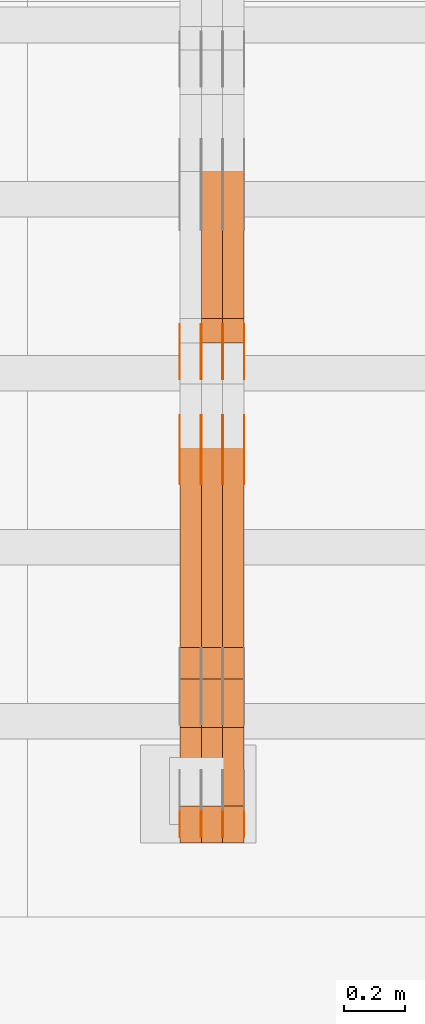
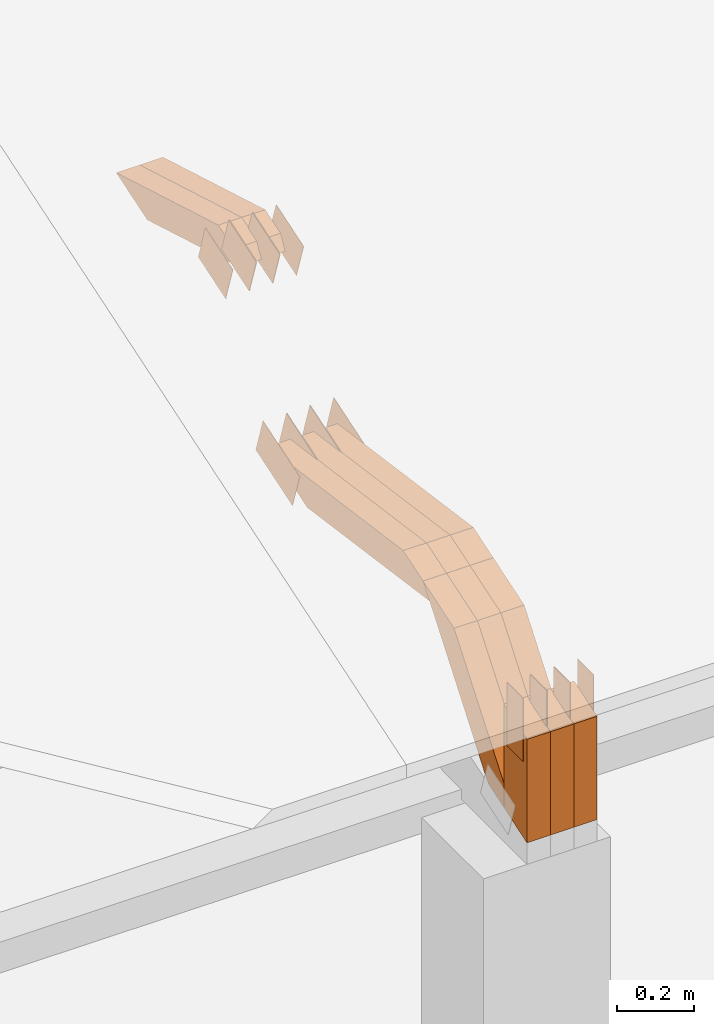
# One storey, part 264 of 385: 29 proxies.
"""IFC2X3 building model written with IfcOpenShell, lengths in millimetres."""

from ifc_helpers import new_model, entity, si_unit, converted_unit, derived_unit, direction, frame, frame_2d, origin, place, context, subcontext, project, spatial, polyline, rectangle, outline, extrude, source, transform, mapped, material, type_object, type_shapes, element, save


model = new_model("IFC2X3")

# Units and contexts
model_context = context("Model", 3, precision=0.01, world=origin(), true_north=direction((6.12303176911189e-17, 1.0)))
body_context = subcontext(model_context, "Body", "Model", "MODEL_VIEW")
ifc_project = project(units=[si_unit("LENGTHUNIT", "METRE", prefix="MILLI"), si_unit("AREAUNIT", "SQUARE_METRE"), si_unit("VOLUMEUNIT", "CUBIC_METRE"), converted_unit("PLANEANGLEUNIT", "DEGREE", entity("IfcRatioMeasure", 0.0174532925199433), si_unit("PLANEANGLEUNIT", "RADIAN"), dimensions=[0, 0, 0, 0, 0, 0, 0]), si_unit("MASSUNIT", "GRAM", prefix="KILO"), derived_unit("MASSDENSITYUNIT", [(si_unit("MASSUNIT", "GRAM", prefix="KILO"), 1), (si_unit("LENGTHUNIT", "METRE"), -3)]), si_unit("TIMEUNIT", "SECOND"), si_unit("FREQUENCYUNIT", "HERTZ"), si_unit("THERMODYNAMICTEMPERATUREUNIT", "DEGREE_CELSIUS"), derived_unit("THERMALTRANSMITTANCEUNIT", [(si_unit("MASSUNIT", "GRAM", prefix="KILO"), 1), (si_unit("THERMODYNAMICTEMPERATUREUNIT", "KELVIN"), -1), (si_unit("TIMEUNIT", "SECOND"), -3)]), derived_unit("VOLUMETRICFLOWRATEUNIT", [(si_unit("LENGTHUNIT", "METRE"), 3), (si_unit("TIMEUNIT", "SECOND"), -1)]), si_unit("ELECTRICCURRENTUNIT", "AMPERE"), si_unit("ELECTRICVOLTAGEUNIT", "VOLT"), si_unit("POWERUNIT", "WATT"), si_unit("FORCEUNIT", "NEWTON", prefix="KILO"), si_unit("ILLUMINANCEUNIT", "LUX"), si_unit("LUMINOUSFLUXUNIT", "LUMEN"), si_unit("LUMINOUSINTENSITYUNIT", "CANDELA"), derived_unit("USERDEFINED", [(si_unit("MASSUNIT", "GRAM", prefix="KILO"), -1), (si_unit("LENGTHUNIT", "METRE"), -2), (si_unit("TIMEUNIT", "SECOND"), 3), (si_unit("LUMINOUSFLUXUNIT", "LUMEN"), 1)]), derived_unit("LINEARVELOCITYUNIT", [(si_unit("LENGTHUNIT", "METRE"), 1), (si_unit("TIMEUNIT", "SECOND"), -1)]), si_unit("PRESSUREUNIT", "PASCAL"), derived_unit("USERDEFINED", [(si_unit("LENGTHUNIT", "METRE"), -2), (si_unit("MASSUNIT", "GRAM", prefix="KILO"), 1), (si_unit("TIMEUNIT", "SECOND"), -2)])], contexts=[model_context])

# Site, building, storey
site_placement = place(None, origin())
site = spatial("IfcSite", under=ifc_project, at=site_placement, CompositionType="ELEMENT")
building_placement = place(site_placement, origin())
building = spatial("IfcBuilding", under=site, at=building_placement, CompositionType="ELEMENT")
storey_placement = place(building_placement, origin())
storey = spatial("IfcBuildingStorey", under=building, at=storey_placement, Name="Default", CompositionType="ELEMENT", Elevation=0.0)

# Proxies
ifc_material_1 = material(Name="IfcSurfaceStyle #511846")
building_element_proxy_type_1 = type_object("IfcBuildingElementProxyType", PredefinedType="NOTDEFINED", material=ifc_material_1)
shared_shape_1 = source(origin(), body_context, "Body", "SweptSolid", [
    extrude(outline(polyline([(-99.9998204243802, -60.000067376167), (99.9998338462265, -60.000067376167), (99.9998204243802, 60.000067376167), (-99.9998338462265, 60.000067376167), (-99.9998204243802, -60.000067376167)])), frame((100.000602015329, 60.0001864986889, 0.0), z_axis=(0.0, 0.0, 1.0), x_axis=(-1.0, 0.0, 0.0)), (0.0, 0.0, 1.0), 1.3),
])
type_shapes(building_element_proxy_type_1, [shared_shape_1])
proxy_1_placement = place(building_placement, frame((42386.3, 4114.85465165112, 513.097031388771), z_axis=(-1.0, 0.0, 0.0), x_axis=(0.0, 0.951056516295124, 0.309016994375039)))
element("IfcBuildingElementProxy", 1, at=proxy_1_placement, inside=storey, type_object=building_element_proxy_type_1, material=ifc_material_1, context=body_context, shape_type="MappedRepresentation", body=[
    mapped(shared_shape_1, transform((0.0, 0.0, 0.0), scale=1.0)),
])
ifc_material_2 = material(Name="IfcSurfaceStyle #511789")
building_element_proxy_type_2 = type_object("IfcBuildingElementProxyType", PredefinedType="NOTDEFINED", material=ifc_material_2)
shared_shape_2 = source(origin(), body_context, "Body", "SweptSolid", [
    extrude(outline(polyline([(-99.9998204243802, -60.000067376167), (99.9998338462265, -60.000067376167), (99.9998204243802, 60.000067376167), (-99.9998338462265, 60.000067376167), (-99.9998204243802, -60.000067376167)])), frame((100.000602015329, 60.0001864986889, 0.0), z_axis=(0.0, 0.0, 1.0), x_axis=(-1.0, 0.0, 0.0)), (0.0, 0.0, 1.0), 1.3),
])
type_shapes(building_element_proxy_type_2, [shared_shape_2])
proxy_2_placement = place(building_placement, frame((42315.0, 4114.85465165112, 513.097031388771), z_axis=(-1.0, 0.0, 0.0), x_axis=(0.0, 0.951056516295124, 0.309016994375039)))
element("IfcBuildingElementProxy", 2, at=proxy_2_placement, inside=storey, type_object=building_element_proxy_type_2, material=ifc_material_2, context=body_context, shape_type="MappedRepresentation", body=[
    mapped(shared_shape_2, transform((0.0, 0.0, 0.0), scale=1.0)),
])
ifc_material_3 = material(Name="IfcSurfaceStyle #511732")
building_element_proxy_type_3 = type_object("IfcBuildingElementProxyType", PredefinedType="NOTDEFINED", material=ifc_material_3)
shared_shape_3 = source(origin(), body_context, "Body", "SweptSolid", [
    extrude(outline(polyline([(-99.9998204243802, -60.000067376167), (99.9998338462265, -60.000067376167), (99.9998204243802, 60.000067376167), (-99.9998338462265, 60.000067376167), (-99.9998204243802, -60.000067376167)])), frame((100.000602015329, 60.0001864986889, 0.0), z_axis=(0.0, 0.0, 1.0), x_axis=(-1.0, 0.0, 0.0)), (0.0, 0.0, 1.0), 1.3),
])
type_shapes(building_element_proxy_type_3, [shared_shape_3])
proxy_3_placement = place(building_placement, frame((42316.3, 4114.85465165112, 513.097031388771), z_axis=(-1.0, 0.0, 0.0), x_axis=(0.0, 0.951056516295124, 0.309016994375039)))
element("IfcBuildingElementProxy", 3, at=proxy_3_placement, inside=storey, type_object=building_element_proxy_type_3, material=ifc_material_3, context=body_context, shape_type="MappedRepresentation", body=[
    mapped(shared_shape_3, transform((0.0, 0.0, 0.0), scale=1.0)),
])
ifc_material_4 = material(Name="IfcSurfaceStyle #511675")
building_element_proxy_type_4 = type_object("IfcBuildingElementProxyType", PredefinedType="NOTDEFINED", material=ifc_material_4)
shared_shape_4 = source(origin(), body_context, "Body", "SweptSolid", [
    extrude(outline(polyline([(-99.9998204243802, -60.000067376167), (99.9998338462265, -60.000067376167), (99.9998204243802, 60.000067376167), (-99.9998338462265, 60.000067376167), (-99.9998204243802, -60.000067376167)])), frame((100.000602015329, 60.0001864986889, 0.0), z_axis=(0.0, 0.0, 1.0), x_axis=(-1.0, 0.0, 0.0)), (0.0, 0.0, 1.0), 1.29999999999998),
])
type_shapes(building_element_proxy_type_4, [shared_shape_4])
proxy_4_placement = place(building_placement, frame((42245.0, 4114.85465165112, 513.097031388771), z_axis=(-1.0, 0.0, 0.0), x_axis=(0.0, 0.951056516295124, 0.309016994375039)))
element("IfcBuildingElementProxy", 4, at=proxy_4_placement, inside=storey, type_object=building_element_proxy_type_4, material=ifc_material_4, context=body_context, shape_type="MappedRepresentation", body=[
    mapped(shared_shape_4, transform((0.0, 0.0, 0.0), scale=1.0)),
])
ifc_material_5 = material(Name="IfcSurfaceStyle #511618")
building_element_proxy_type_5 = type_object("IfcBuildingElementProxyType", PredefinedType="NOTDEFINED", material=ifc_material_5)
shared_shape_5 = source(origin(), body_context, "Body", "SweptSolid", [
    extrude(outline(polyline([(-99.9998204243802, -60.000067376167), (99.9998338462265, -60.000067376167), (99.9998204243802, 60.000067376167), (-99.9998338462265, 60.000067376167), (-99.9998204243802, -60.000067376167)])), frame((100.000602015329, 60.0001864986889, 0.0), z_axis=(0.0, 0.0, 1.0), x_axis=(-1.0, 0.0, 0.0)), (0.0, 0.0, 1.0), 1.29999999999998),
])
type_shapes(building_element_proxy_type_5, [shared_shape_5])
proxy_5_placement = place(building_placement, frame((42246.3, 4114.85465165112, 513.097031388771), z_axis=(-1.0, 0.0, 0.0), x_axis=(0.0, 0.951056516295124, 0.309016994375039)))
element("IfcBuildingElementProxy", 5, at=proxy_5_placement, inside=storey, type_object=building_element_proxy_type_5, material=ifc_material_5, context=body_context, shape_type="MappedRepresentation", body=[
    mapped(shared_shape_5, transform((0.0, 0.0, 0.0), scale=1.0)),
])
ifc_material_6 = material(Name="IfcSurfaceStyle #511561")
building_element_proxy_type_6 = type_object("IfcBuildingElementProxyType", PredefinedType="NOTDEFINED", material=ifc_material_6)
shared_shape_6 = source(origin(), body_context, "Body", "SweptSolid", [
    extrude(outline(polyline([(-99.9998204243802, -60.000067376167), (99.9998338462265, -60.000067376167), (99.9998204243802, 60.000067376167), (-99.9998338462265, 60.000067376167), (-99.9998204243802, -60.000067376167)])), frame((100.000602015329, 60.0001864986889, 0.0), z_axis=(0.0, 0.0, 1.0), x_axis=(-1.0, 0.0, 0.0)), (0.0, 0.0, 1.0), 1.29999999999999),
])
type_shapes(building_element_proxy_type_6, [shared_shape_6])
proxy_6_placement = place(building_placement, frame((42175.0, 4114.85465165112, 513.097031388771), z_axis=(-1.0, 0.0, 0.0), x_axis=(0.0, 0.951056516295124, 0.309016994375039)))
element("IfcBuildingElementProxy", 6, at=proxy_6_placement, inside=storey, type_object=building_element_proxy_type_6, material=ifc_material_6, context=body_context, shape_type="MappedRepresentation", body=[
    mapped(shared_shape_6, transform((0.0, 0.0, 0.0), scale=1.0)),
])
ifc_material_7 = material(Name="IfcSurfaceStyle #504664")
building_element_proxy_type_7 = type_object("IfcBuildingElementProxyType", PredefinedType="NOTDEFINED", material=ifc_material_7)
shared_shape_7 = source(origin(), body_context, "Body", "SweptSolid", [
    extrude(outline(polyline([(-74.999865998172, -60.0000306612919), (74.999869989555, -60.0000306612919), (74.999865998172, 60.0000306612919), (-74.999869989555, 60.0000306612919), (-74.999865998172, -60.0000306612919)])), frame((75.0006726017528, 60.0001996460842, 0.0), z_axis=(0.0, 0.0, 1.0), x_axis=(-1.0, 0.0, 0.0)), (0.0, 0.0, 1.0), 1.3),
])
type_shapes(building_element_proxy_type_7, [shared_shape_7])
proxy_7_placement = place(building_placement, frame((42386.3, 4460.38978242656, 957.314497110567), z_axis=(-1.0, 0.0, 0.0), x_axis=(0.0, 0.951056516295154, 0.309016994374948)))
element("IfcBuildingElementProxy", 7, at=proxy_7_placement, inside=storey, type_object=building_element_proxy_type_7, material=ifc_material_7, context=body_context, shape_type="MappedRepresentation", body=[
    mapped(shared_shape_7, transform((0.0, 0.0, 0.0), scale=1.0)),
])
ifc_material_8 = material(Name="IfcSurfaceStyle #504607")
building_element_proxy_type_8 = type_object("IfcBuildingElementProxyType", PredefinedType="NOTDEFINED", material=ifc_material_8)
shared_shape_8 = source(origin(), body_context, "Body", "SweptSolid", [
    extrude(outline(polyline([(-74.999865998172, -60.0000306612919), (74.999869989555, -60.0000306612919), (74.999865998172, 60.0000306612919), (-74.999869989555, 60.0000306612919), (-74.999865998172, -60.0000306612919)])), frame((75.0006726017528, 60.0001996460842, 0.0), z_axis=(0.0, 0.0, 1.0), x_axis=(-1.0, 0.0, 0.0)), (0.0, 0.0, 1.0), 1.3),
])
type_shapes(building_element_proxy_type_8, [shared_shape_8])
proxy_8_placement = place(building_placement, frame((42315.0, 4460.38978242656, 957.314497110567), z_axis=(-1.0, 0.0, 0.0), x_axis=(0.0, 0.951056516295154, 0.309016994374948)))
element("IfcBuildingElementProxy", 8, at=proxy_8_placement, inside=storey, type_object=building_element_proxy_type_8, material=ifc_material_8, context=body_context, shape_type="MappedRepresentation", body=[
    mapped(shared_shape_8, transform((0.0, 0.0, 0.0), scale=1.0)),
])
ifc_material_9 = material(Name="IfcSurfaceStyle #504550")
building_element_proxy_type_9 = type_object("IfcBuildingElementProxyType", PredefinedType="NOTDEFINED", material=ifc_material_9)
shared_shape_9 = source(origin(), body_context, "Body", "SweptSolid", [
    extrude(outline(polyline([(-74.999865998172, -60.0000306612919), (74.999869989555, -60.0000306612919), (74.999865998172, 60.0000306612919), (-74.999869989555, 60.0000306612919), (-74.999865998172, -60.0000306612919)])), frame((75.0006726017528, 60.0001996460842, 0.0), z_axis=(0.0, 0.0, 1.0), x_axis=(-1.0, 0.0, 0.0)), (0.0, 0.0, 1.0), 1.3),
])
type_shapes(building_element_proxy_type_9, [shared_shape_9])
proxy_9_placement = place(building_placement, frame((42316.3, 4460.38978242656, 957.314497110567), z_axis=(-1.0, 0.0, 0.0), x_axis=(0.0, 0.951056516295154, 0.309016994374948)))
element("IfcBuildingElementProxy", 9, at=proxy_9_placement, inside=storey, type_object=building_element_proxy_type_9, material=ifc_material_9, context=body_context, shape_type="MappedRepresentation", body=[
    mapped(shared_shape_9, transform((0.0, 0.0, 0.0), scale=1.0)),
])
ifc_material_10 = material(Name="IfcSurfaceStyle #504493")
building_element_proxy_type_10 = type_object("IfcBuildingElementProxyType", PredefinedType="NOTDEFINED", material=ifc_material_10)
shared_shape_10 = source(origin(), body_context, "Body", "SweptSolid", [
    extrude(outline(polyline([(-74.999865998172, -60.0000306612919), (74.999869989555, -60.0000306612919), (74.999865998172, 60.0000306612919), (-74.999869989555, 60.0000306612919), (-74.999865998172, -60.0000306612919)])), frame((75.0006726017528, 60.0001996460842, 0.0), z_axis=(0.0, 0.0, 1.0), x_axis=(-1.0, 0.0, 0.0)), (0.0, 0.0, 1.0), 1.29999999999999),
])
type_shapes(building_element_proxy_type_10, [shared_shape_10])
proxy_10_placement = place(building_placement, frame((42245.0, 4460.38978242656, 957.314497110567), z_axis=(-1.0, 0.0, 0.0), x_axis=(0.0, 0.951056516295154, 0.309016994374948)))
element("IfcBuildingElementProxy", 10, at=proxy_10_placement, inside=storey, type_object=building_element_proxy_type_10, material=ifc_material_10, context=body_context, shape_type="MappedRepresentation", body=[
    mapped(shared_shape_10, transform((0.0, 0.0, 0.0), scale=1.0)),
])
ifc_material_11 = material(Name="IfcSurfaceStyle #504436")
building_element_proxy_type_11 = type_object("IfcBuildingElementProxyType", PredefinedType="NOTDEFINED", material=ifc_material_11)
shared_shape_11 = source(origin(), body_context, "Body", "SweptSolid", [
    extrude(outline(polyline([(-74.999865998172, -60.0000306612919), (74.999869989555, -60.0000306612919), (74.999865998172, 60.0000306612919), (-74.999869989555, 60.0000306612919), (-74.999865998172, -60.0000306612919)])), frame((75.0006726017528, 60.0001996460842, 0.0), z_axis=(0.0, 0.0, 1.0), x_axis=(-1.0, 0.0, 0.0)), (0.0, 0.0, 1.0), 1.29999999999999),
])
type_shapes(building_element_proxy_type_11, [shared_shape_11])
proxy_11_placement = place(building_placement, frame((42246.3, 4460.38978242656, 957.314497110567), z_axis=(-1.0, 0.0, 0.0), x_axis=(0.0, 0.951056516295154, 0.309016994374948)))
element("IfcBuildingElementProxy", 11, at=proxy_11_placement, inside=storey, type_object=building_element_proxy_type_11, material=ifc_material_11, context=body_context, shape_type="MappedRepresentation", body=[
    mapped(shared_shape_11, transform((0.0, 0.0, 0.0), scale=1.0)),
])
ifc_material_12 = material(Name="IfcSurfaceStyle #504379")
building_element_proxy_type_12 = type_object("IfcBuildingElementProxyType", PredefinedType="NOTDEFINED", material=ifc_material_12)
shared_shape_12 = source(origin(), body_context, "Body", "SweptSolid", [
    extrude(outline(polyline([(-74.999865998172, -60.0000306612919), (74.999869989555, -60.0000306612919), (74.999865998172, 60.0000306612919), (-74.999869989555, 60.0000306612919), (-74.999865998172, -60.0000306612919)])), frame((75.0006726017528, 60.0001996460842, 0.0), z_axis=(0.0, 0.0, 1.0), x_axis=(-1.0, 0.0, 0.0)), (0.0, 0.0, 1.0), 1.29999999999999),
])
type_shapes(building_element_proxy_type_12, [shared_shape_12])
proxy_12_placement = place(building_placement, frame((42175.0, 4460.38978242656, 957.314497110567), z_axis=(-1.0, 0.0, 0.0), x_axis=(0.0, 0.951056516295154, 0.309016994374948)))
element("IfcBuildingElementProxy", 12, at=proxy_12_placement, inside=storey, type_object=building_element_proxy_type_12, material=ifc_material_12, context=body_context, shape_type="MappedRepresentation", body=[
    mapped(shared_shape_12, transform((0.0, 0.0, 0.0), scale=1.0)),
])
ifc_material_13 = material(Name="IfcSurfaceStyle #502612")
building_element_proxy_type_13 = type_object("IfcBuildingElementProxyType", PredefinedType="NOTDEFINED", material=ifc_material_13)
shared_shape_13 = source(origin(), body_context, "Body", "SweptSolid", [
    extrude(rectangle(XDim=199.999969482422, YDim=84.0, at=frame_2d((1.4210854715202e-14, 0.0), x_axis=(1.0, 0.0))), frame((100.000010815955, 42.0, 0.0), z_axis=(0.0, 0.0, 1.0), x_axis=(-1.0, 0.0, 0.0)), (0.0, 0.0, 1.0), 1.3),
])
type_shapes(building_element_proxy_type_13, [shared_shape_13])
proxy_13_placement = place(building_placement, frame((42386.3, 3042.0, 514.460048047401), z_axis=(-1.0, 0.0, 0.0), x_axis=(0.0, 0.0, -1.0)))
element("IfcBuildingElementProxy", 13, at=proxy_13_placement, inside=storey, type_object=building_element_proxy_type_13, material=ifc_material_13, context=body_context, shape_type="MappedRepresentation", body=[
    mapped(shared_shape_13, transform((0.0, 0.0, 0.0), scale=1.0)),
])
ifc_material_14 = material(Name="IfcSurfaceStyle #502555")
building_element_proxy_type_14 = type_object("IfcBuildingElementProxyType", PredefinedType="NOTDEFINED", material=ifc_material_14)
shared_shape_14 = source(origin(), body_context, "Body", "SweptSolid", [
    extrude(rectangle(XDim=199.999969482422, YDim=84.0, at=frame_2d((1.4210854715202e-14, 0.0), x_axis=(1.0, 0.0))), frame((100.000010815955, 42.0, 0.0), z_axis=(0.0, 0.0, 1.0), x_axis=(-1.0, 0.0, 0.0)), (0.0, 0.0, 1.0), 1.3),
])
type_shapes(building_element_proxy_type_14, [shared_shape_14])
proxy_14_placement = place(building_placement, frame((42315.0, 3042.0, 514.460048047401), z_axis=(-1.0, 0.0, 0.0), x_axis=(0.0, 0.0, -1.0)))
element("IfcBuildingElementProxy", 14, at=proxy_14_placement, inside=storey, type_object=building_element_proxy_type_14, material=ifc_material_14, context=body_context, shape_type="MappedRepresentation", body=[
    mapped(shared_shape_14, transform((0.0, 0.0, 0.0), scale=1.0)),
])
ifc_material_15 = material(Name="IfcSurfaceStyle #502498")
building_element_proxy_type_15 = type_object("IfcBuildingElementProxyType", PredefinedType="NOTDEFINED", material=ifc_material_15)
shared_shape_15 = source(origin(), body_context, "Body", "SweptSolid", [
    extrude(rectangle(XDim=199.999969482422, YDim=84.0, at=frame_2d((1.4210854715202e-14, 0.0), x_axis=(1.0, 0.0))), frame((100.000010815955, 42.0, 0.0), z_axis=(0.0, 0.0, 1.0), x_axis=(-1.0, 0.0, 0.0)), (0.0, 0.0, 1.0), 1.3),
])
type_shapes(building_element_proxy_type_15, [shared_shape_15])
proxy_15_placement = place(building_placement, frame((42316.3, 3042.0, 514.460048047401), z_axis=(-1.0, 0.0, 0.0), x_axis=(0.0, 0.0, -1.0)))
element("IfcBuildingElementProxy", 15, at=proxy_15_placement, inside=storey, type_object=building_element_proxy_type_15, material=ifc_material_15, context=body_context, shape_type="MappedRepresentation", body=[
    mapped(shared_shape_15, transform((0.0, 0.0, 0.0), scale=1.0)),
])
ifc_material_16 = material(Name="IfcSurfaceStyle #502441")
building_element_proxy_type_16 = type_object("IfcBuildingElementProxyType", PredefinedType="NOTDEFINED", material=ifc_material_16)
shared_shape_16 = source(origin(), body_context, "Body", "SweptSolid", [
    extrude(rectangle(XDim=199.999969482422, YDim=84.0, at=frame_2d((1.4210854715202e-14, 0.0), x_axis=(1.0, 0.0))), frame((100.000010815955, 42.0, 0.0), z_axis=(0.0, 0.0, 1.0), x_axis=(-1.0, 0.0, 0.0)), (0.0, 0.0, 1.0), 1.29999999999998),
])
type_shapes(building_element_proxy_type_16, [shared_shape_16])
proxy_16_placement = place(building_placement, frame((42245.0, 3042.0, 514.460048047401), z_axis=(-1.0, 0.0, 0.0), x_axis=(0.0, 0.0, -1.0)))
element("IfcBuildingElementProxy", 16, at=proxy_16_placement, inside=storey, type_object=building_element_proxy_type_16, material=ifc_material_16, context=body_context, shape_type="MappedRepresentation", body=[
    mapped(shared_shape_16, transform((0.0, 0.0, 0.0), scale=1.0)),
])
ifc_material_17 = material(Name="IfcSurfaceStyle #502384")
building_element_proxy_type_17 = type_object("IfcBuildingElementProxyType", PredefinedType="NOTDEFINED", material=ifc_material_17)
shared_shape_17 = source(origin(), body_context, "Body", "SweptSolid", [
    extrude(rectangle(XDim=199.999969482422, YDim=84.0, at=frame_2d((1.4210854715202e-14, 0.0), x_axis=(1.0, 0.0))), frame((100.000010815955, 42.0, 0.0), z_axis=(0.0, 0.0, 1.0), x_axis=(-1.0, 0.0, 0.0)), (0.0, 0.0, 1.0), 1.29999999999998),
])
type_shapes(building_element_proxy_type_17, [shared_shape_17])
proxy_17_placement = place(building_placement, frame((42246.3, 3042.0, 514.460048047401), z_axis=(-1.0, 0.0, 0.0), x_axis=(0.0, 0.0, -1.0)))
element("IfcBuildingElementProxy", 17, at=proxy_17_placement, inside=storey, type_object=building_element_proxy_type_17, material=ifc_material_17, context=body_context, shape_type="MappedRepresentation", body=[
    mapped(shared_shape_17, transform((0.0, 0.0, 0.0), scale=1.0)),
])
ifc_material_18 = material(Name="IfcSurfaceStyle #502327")
building_element_proxy_type_18 = type_object("IfcBuildingElementProxyType", PredefinedType="NOTDEFINED", material=ifc_material_18)
shared_shape_18 = source(origin(), body_context, "Body", "SweptSolid", [
    extrude(rectangle(XDim=199.999969482422, YDim=84.0, at=frame_2d((1.4210854715202e-14, 0.0), x_axis=(1.0, 0.0))), frame((100.000010815955, 42.0, 0.0), z_axis=(0.0, 0.0, 1.0), x_axis=(-1.0, 0.0, 0.0)), (0.0, 0.0, 1.0), 1.29999999999999),
])
type_shapes(building_element_proxy_type_18, [shared_shape_18])
proxy_18_placement = place(building_placement, frame((42175.0, 3042.0, 514.460048047401), z_axis=(-1.0, 0.0, 0.0), x_axis=(0.0, 0.0, -1.0)))
element("IfcBuildingElementProxy", 18, at=proxy_18_placement, inside=storey, type_object=building_element_proxy_type_18, material=ifc_material_18, context=body_context, shape_type="MappedRepresentation", body=[
    mapped(shared_shape_18, transform((0.0, 0.0, 0.0), scale=1.0)),
])
ifc_material_19 = material(Name="IfcSurfaceStyle #492136")
building_element_proxy_type_19 = type_object("IfcBuildingElementProxyType", Name="T1-W12 492134", PredefinedType="NOTDEFINED", material=ifc_material_19)
shared_shape_19 = source(origin(), body_context, "Body", "SweptSolid", [
    extrude(outline(polyline([(-249.405625983165, -47.5001691155616), (243.345753908996, -47.5001691155616), (232.115534842595, 2.39993474701938e-05), (162.527010966644, 47.5001571158879), (-388.58267373507, 47.5001571158879), (-249.405625983165, -47.5001691155616)])), frame((243.345867653852, 47.5001571158879, 0.0), z_axis=(0.0, 0.0, 1.0), x_axis=(-1.0, 0.0, 0.0)), (0.0, 0.0, 1.0), 70.0),
])
type_shapes(building_element_proxy_type_19, [shared_shape_19])
proxy_19_placement = place(building_placement, frame((42385.0, 4581.32698473632, 976.172276753357), z_axis=(-1.0, 0.0, 0.0), x_axis=(0.0, 0.959722067881787, -0.280951156645966)))
element("IfcBuildingElementProxy", 19, at=proxy_19_placement, inside=storey, type_object=building_element_proxy_type_19, material=ifc_material_19, Name="T1-W12", context=body_context, shape_type="MappedRepresentation", body=[
    mapped(shared_shape_19, transform((0.0, 0.0, 0.0), scale=1.0)),
])
ifc_material_20 = material(Name="IfcSurfaceStyle #492070")
building_element_proxy_type_20 = type_object("IfcBuildingElementProxyType", Name="T1-W12 492068", PredefinedType="NOTDEFINED", material=ifc_material_20)
shared_shape_20 = source(origin(), body_context, "Body", "SweptSolid", [
    extrude(outline(polyline([(-249.405625983165, -47.5001691155616), (243.345753908996, -47.5001691155616), (232.115534842595, 2.39993474701938e-05), (162.527010966644, 47.5001571158879), (-388.58267373507, 47.5001571158879), (-249.405625983165, -47.5001691155616)])), frame((243.345867653852, 47.5001571158879, 0.0), z_axis=(0.0, 0.0, 1.0), x_axis=(-1.0, 0.0, 0.0)), (0.0, 0.0, 1.0), 70.0),
])
type_shapes(building_element_proxy_type_20, [shared_shape_20])
proxy_20_placement = place(building_placement, frame((42315.0, 4581.32698473632, 976.172276753357), z_axis=(-1.0, 0.0, 0.0), x_axis=(0.0, 0.959722067881787, -0.280951156645966)))
element("IfcBuildingElementProxy", 20, at=proxy_20_placement, inside=storey, type_object=building_element_proxy_type_20, material=ifc_material_20, Name="T1-W12", context=body_context, shape_type="MappedRepresentation", body=[
    mapped(shared_shape_20, transform((0.0, 0.0, 0.0), scale=1.0)),
])
ifc_material_21 = material(Name="IfcSurfaceStyle #491344")
building_element_proxy_type_21 = type_object("IfcBuildingElementProxyType", Name="T1-W3 491342", PredefinedType="NOTDEFINED", material=ifc_material_21)
shared_shape_21 = source(origin(), body_context, "Body", "SweptSolid", [
    extrude(outline(polyline([(-314.232579911788, -47.5000200125938), (325.164873061766, -47.5000200125938), (297.999869081008, 6.48085173424295e-05), (200.434027234171, 47.4999876083351), (-509.366189465157, 47.4999876083352), (-314.232579911788, -47.5000200125938)])), frame((325.164873061766, 47.5001564752191, 0.0), z_axis=(0.0, 0.0, 1.0), x_axis=(-1.0, 0.0, 0.0)), (0.0, 0.0, 1.0), 70.0),
])
type_shapes(building_element_proxy_type_21, [shared_shape_21])
proxy_21_placement = place(building_placement, frame((42385.0, 3457.43747924876, 620.49890325051), z_axis=(-1.0, 0.0, 0.0), x_axis=(0.0, 0.990367219823621, -0.138465771578512)))
element("IfcBuildingElementProxy", 21, at=proxy_21_placement, inside=storey, type_object=building_element_proxy_type_21, material=ifc_material_21, Name="T1-W3", context=body_context, shape_type="MappedRepresentation", body=[
    mapped(shared_shape_21, transform((0.0, 0.0, 0.0), scale=1.0)),
])
ifc_material_22 = material(Name="IfcSurfaceStyle #491278")
building_element_proxy_type_22 = type_object("IfcBuildingElementProxyType", Name="T1-W3 491276", PredefinedType="NOTDEFINED", material=ifc_material_22)
shared_shape_22 = source(origin(), body_context, "Body", "SweptSolid", [
    extrude(outline(polyline([(-314.232579911788, -47.5000200125938), (325.164873061766, -47.5000200125938), (297.999869081008, 6.48085173424295e-05), (200.434027234171, 47.4999876083351), (-509.366189465157, 47.4999876083352), (-314.232579911788, -47.5000200125938)])), frame((325.164873061766, 47.5001564752191, 0.0), z_axis=(0.0, 0.0, 1.0), x_axis=(-1.0, 0.0, 0.0)), (0.0, 0.0, 1.0), 70.0),
])
type_shapes(building_element_proxy_type_22, [shared_shape_22])
proxy_22_placement = place(building_placement, frame((42315.0, 3457.43747924876, 620.49890325051), z_axis=(-1.0, 0.0, 0.0), x_axis=(0.0, 0.990367219823621, -0.138465771578512)))
element("IfcBuildingElementProxy", 22, at=proxy_22_placement, inside=storey, type_object=building_element_proxy_type_22, material=ifc_material_22, Name="T1-W3", context=body_context, shape_type="MappedRepresentation", body=[
    mapped(shared_shape_22, transform((0.0, 0.0, 0.0), scale=1.0)),
])
ifc_material_23 = material(Name="IfcSurfaceStyle #491212")
building_element_proxy_type_23 = type_object("IfcBuildingElementProxyType", Name="T1-W3 491210", PredefinedType="NOTDEFINED", material=ifc_material_23)
shared_shape_23 = source(origin(), body_context, "Body", "SweptSolid", [
    extrude(outline(polyline([(-314.232579911788, -47.5000200125938), (325.164873061766, -47.5000200125938), (297.999869081008, 6.48085173424295e-05), (200.434027234171, 47.4999876083351), (-509.366189465157, 47.4999876083352), (-314.232579911788, -47.5000200125938)])), frame((325.164873061766, 47.5001564752191, 0.0), z_axis=(0.0, 0.0, 1.0), x_axis=(-1.0, 0.0, 0.0)), (0.0, 0.0, 1.0), 70.0),
])
type_shapes(building_element_proxy_type_23, [shared_shape_23])
proxy_23_placement = place(building_placement, frame((42245.0, 3457.43747924876, 620.49890325051), z_axis=(-1.0, 0.0, 0.0), x_axis=(0.0, 0.990367219823621, -0.138465771578512)))
element("IfcBuildingElementProxy", 23, at=proxy_23_placement, inside=storey, type_object=building_element_proxy_type_23, material=ifc_material_23, Name="T1-W3", context=body_context, shape_type="MappedRepresentation", body=[
    mapped(shared_shape_23, transform((0.0, 0.0, 0.0), scale=1.0)),
])
ifc_material_24 = material(Name="IfcSurfaceStyle #490948")
building_element_proxy_type_24 = type_object("IfcBuildingElementProxyType", Name="T1-W14 490946", PredefinedType="NOTDEFINED", material=ifc_material_24)
shared_shape_24 = source(origin(), body_context, "Body", "SweptSolid", [
    extrude(outline(polyline([(-374.484689776928, -47.499919737532), (177.199556189275, -47.499919737532), (246.893257937645, -5.36774925340877e-05), (185.487930694801, 47.4999465762783), (-235.096055044793, 47.4999465762784), (-374.484689776928, -47.499919737532)])), frame((246.893257937645, 47.5000959779252, 0.0), z_axis=(0.0, 0.0, 1.0), x_axis=(-1.0, 0.0, 0.0)), (0.0, 0.0, 1.0), 70.0),
])
type_shapes(building_element_proxy_type_24, [shared_shape_24])
proxy_24_placement = place(building_placement, frame((42385.0, 3022.42877773025, 136.329406512195), z_axis=(-1.0, 0.0, 0.0), x_axis=(0.0, 0.611854146609475, 0.790970608352037)))
element("IfcBuildingElementProxy", 24, at=proxy_24_placement, inside=storey, type_object=building_element_proxy_type_24, material=ifc_material_24, Name="T1-W14", context=body_context, shape_type="MappedRepresentation", body=[
    mapped(shared_shape_24, transform((0.0, 0.0, 0.0), scale=1.0)),
])
ifc_material_25 = material(Name="IfcSurfaceStyle #490882")
building_element_proxy_type_25 = type_object("IfcBuildingElementProxyType", Name="T1-W14 490880", PredefinedType="NOTDEFINED", material=ifc_material_25)
shared_shape_25 = source(origin(), body_context, "Body", "SweptSolid", [
    extrude(outline(polyline([(-374.484689776928, -47.499919737532), (177.199556189275, -47.499919737532), (246.893257937645, -5.36774925340877e-05), (185.487930694801, 47.4999465762783), (-235.096055044793, 47.4999465762784), (-374.484689776928, -47.499919737532)])), frame((246.893257937645, 47.5000959779252, 0.0), z_axis=(0.0, 0.0, 1.0), x_axis=(-1.0, 0.0, 0.0)), (0.0, 0.0, 1.0), 70.0),
])
type_shapes(building_element_proxy_type_25, [shared_shape_25])
proxy_25_placement = place(building_placement, frame((42315.0, 3022.42877773025, 136.329406512195), z_axis=(-1.0, 0.0, 0.0), x_axis=(0.0, 0.611854146609475, 0.790970608352037)))
element("IfcBuildingElementProxy", 25, at=proxy_25_placement, inside=storey, type_object=building_element_proxy_type_25, material=ifc_material_25, Name="T1-W14", context=body_context, shape_type="MappedRepresentation", body=[
    mapped(shared_shape_25, transform((0.0, 0.0, 0.0), scale=1.0)),
])
ifc_material_26 = material(Name="IfcSurfaceStyle #490816")
building_element_proxy_type_26 = type_object("IfcBuildingElementProxyType", Name="T1-W14 490814", PredefinedType="NOTDEFINED", material=ifc_material_26)
shared_shape_26 = source(origin(), body_context, "Body", "SweptSolid", [
    extrude(outline(polyline([(-374.484689776928, -47.499919737532), (177.199556189275, -47.499919737532), (246.893257937645, -5.36774925340877e-05), (185.487930694801, 47.4999465762783), (-235.096055044793, 47.4999465762784), (-374.484689776928, -47.499919737532)])), frame((246.893257937645, 47.5000959779252, 0.0), z_axis=(0.0, 0.0, 1.0), x_axis=(-1.0, 0.0, 0.0)), (0.0, 0.0, 1.0), 70.0),
])
type_shapes(building_element_proxy_type_26, [shared_shape_26])
proxy_26_placement = place(building_placement, frame((42245.0, 3022.42877773025, 136.329406512195), z_axis=(-1.0, 0.0, 0.0), x_axis=(0.0, 0.611854146609475, 0.790970608352037)))
element("IfcBuildingElementProxy", 26, at=proxy_26_placement, inside=storey, type_object=building_element_proxy_type_26, material=ifc_material_26, Name="T1-W14", context=body_context, shape_type="MappedRepresentation", body=[
    mapped(shared_shape_26, transform((0.0, 0.0, 0.0), scale=1.0)),
])
ifc_material_27 = material(Name="IfcSurfaceStyle #490750")
building_element_proxy_type_27 = type_object("IfcBuildingElementProxyType", Name="T1-E3 490748", PredefinedType="NOTDEFINED", material=ifc_material_27)
shared_shape_27 = source(origin(), body_context, "Body", "SweptSolid", [
    extrude(outline(polyline([(-182.839673995971, -60.0), (143.849313735962, -60.0), (182.839677810669, 60.0), (-143.84931755066, 60.0), (-182.839673995971, -60.0)])), frame((182.839677810669, 60.0, 0.0), z_axis=(0.0, 0.0, 1.0), x_axis=(-1.0, 0.0, 0.0)), (0.0, 0.0, 1.0), 70.0),
])
type_shapes(building_element_proxy_type_27, [shared_shape_27])
proxy_27_placement = place(building_placement, frame((42385.0, 2940.0, 68.27587890625), z_axis=(-1.0, 0.0, 0.0), x_axis=(0.0, 0.0, 1.0)))
element("IfcBuildingElementProxy", 27, at=proxy_27_placement, inside=storey, type_object=building_element_proxy_type_27, material=ifc_material_27, Name="T1-E3", context=body_context, shape_type="MappedRepresentation", body=[
    mapped(shared_shape_27, transform((0.0, 0.0, 0.0), scale=1.0)),
])
ifc_material_28 = material(Name="IfcSurfaceStyle #490693")
building_element_proxy_type_28 = type_object("IfcBuildingElementProxyType", Name="T1-E3 490691", PredefinedType="NOTDEFINED", material=ifc_material_28)
shared_shape_28 = source(origin(), body_context, "Body", "SweptSolid", [
    extrude(outline(polyline([(-182.839673995971, -60.0), (143.849313735962, -60.0), (182.839677810669, 60.0), (-143.84931755066, 60.0), (-182.839673995971, -60.0)])), frame((182.839677810669, 60.0, 0.0), z_axis=(0.0, 0.0, 1.0), x_axis=(-1.0, 0.0, 0.0)), (0.0, 0.0, 1.0), 70.0),
])
type_shapes(building_element_proxy_type_28, [shared_shape_28])
proxy_28_placement = place(building_placement, frame((42315.0, 2940.0, 68.27587890625), z_axis=(-1.0, 0.0, 0.0), x_axis=(0.0, 0.0, 1.0)))
element("IfcBuildingElementProxy", 28, at=proxy_28_placement, inside=storey, type_object=building_element_proxy_type_28, material=ifc_material_28, Name="T1-E3", context=body_context, shape_type="MappedRepresentation", body=[
    mapped(shared_shape_28, transform((0.0, 0.0, 0.0), scale=1.0)),
])
ifc_material_29 = material(Name="IfcSurfaceStyle #490636")
building_element_proxy_type_29 = type_object("IfcBuildingElementProxyType", Name="T1-E3 490634", PredefinedType="NOTDEFINED", material=ifc_material_29)
shared_shape_29 = source(origin(), body_context, "Body", "SweptSolid", [
    extrude(outline(polyline([(-182.839673995971, -60.0), (143.849313735962, -60.0), (182.839677810669, 60.0), (-143.84931755066, 60.0), (-182.839673995971, -60.0)])), frame((182.839677810669, 60.0, 0.0), z_axis=(0.0, 0.0, 1.0), x_axis=(-1.0, 0.0, 0.0)), (0.0, 0.0, 1.0), 70.0),
])
type_shapes(building_element_proxy_type_29, [shared_shape_29])
proxy_29_placement = place(building_placement, frame((42245.0, 2940.0, 68.27587890625), z_axis=(-1.0, 0.0, 0.0), x_axis=(0.0, 0.0, 1.0)))
element("IfcBuildingElementProxy", 29, at=proxy_29_placement, inside=storey, type_object=building_element_proxy_type_29, material=ifc_material_29, Name="T1-E3", context=body_context, shape_type="MappedRepresentation", body=[
    mapped(shared_shape_29, transform((0.0, 0.0, 0.0), scale=1.0)),
])

save(model, "model.ifc")
